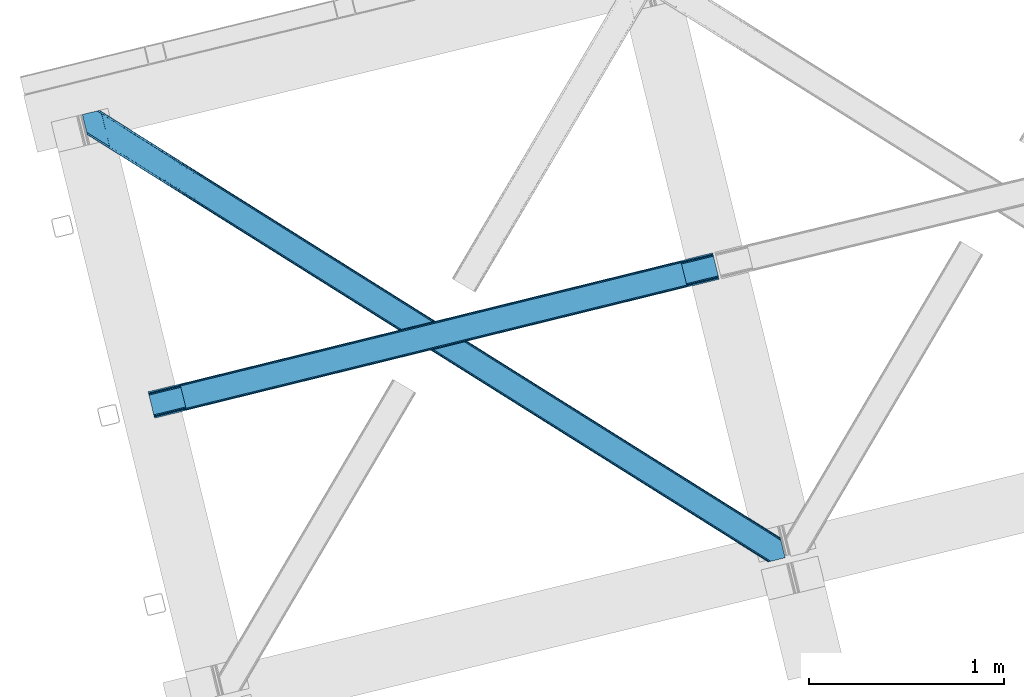
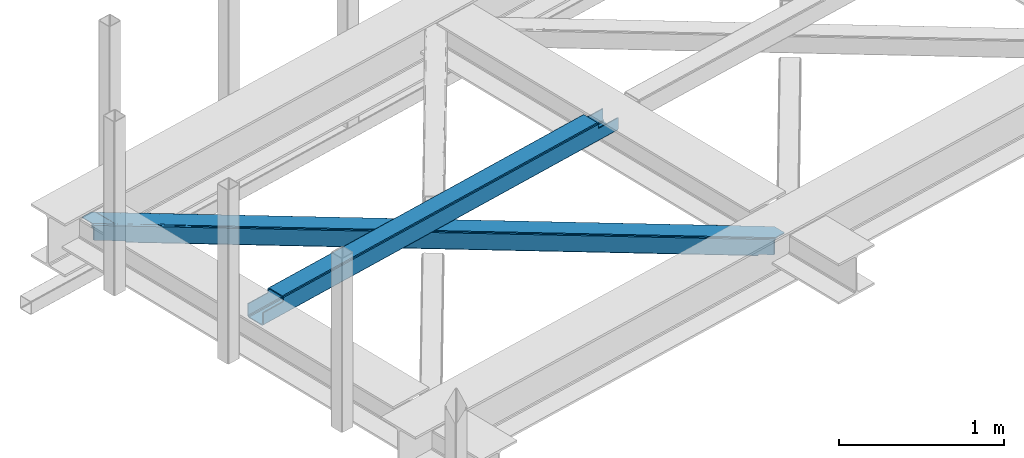
# One storey, part 18 of 66: 1 beam, 1 member.
"""IFC4 building model written with IfcOpenShell, lengths in millimetres."""

from ifc_helpers import new_model, entity, si_unit, converted_unit, derived_unit, direction, frame, origin, place, context, subcontext, project, spatial, triangles, polygons, material, type_object, element, save


model = new_model("IFC4")

# Units and contexts
model_context = context("Model", 3, precision=0.01, world=origin(), true_north=direction((6.12303176911189e-17, 1.0)))
plan_context = context("Plan", 3, precision=0.01, world=origin(), true_north=direction((6.12303176911189e-17, 1.0)))
body_context = subcontext(model_context, "Body", "Model", "MODEL_VIEW")
ifc_project = project(units=[si_unit("LENGTHUNIT", "METRE", prefix="MILLI"), si_unit("AREAUNIT", "SQUARE_METRE"), si_unit("VOLUMEUNIT", "CUBIC_METRE"), converted_unit("PLANEANGLEUNIT", "DEGREE", entity("IfcRatioMeasure", 0.0174532925199433), si_unit("PLANEANGLEUNIT", "RADIAN"), dimensions=[0, 0, 0, 0, 0, 0, 0]), si_unit("MASSUNIT", "GRAM", prefix="KILO"), derived_unit("MASSDENSITYUNIT", [(si_unit("MASSUNIT", "GRAM", prefix="KILO"), 1), (si_unit("LENGTHUNIT", "METRE"), -3)]), derived_unit("MOMENTOFINERTIAUNIT", [(si_unit("LENGTHUNIT", "METRE"), 4)]), si_unit("TIMEUNIT", "SECOND"), si_unit("FREQUENCYUNIT", "HERTZ"), si_unit("THERMODYNAMICTEMPERATUREUNIT", "DEGREE_CELSIUS"), derived_unit("THERMALTRANSMITTANCEUNIT", [(si_unit("MASSUNIT", "GRAM", prefix="KILO"), 1), (si_unit("THERMODYNAMICTEMPERATUREUNIT", "KELVIN"), -1), (si_unit("TIMEUNIT", "SECOND"), -3)]), derived_unit("VOLUMETRICFLOWRATEUNIT", [(si_unit("LENGTHUNIT", "METRE"), 3), (si_unit("TIMEUNIT", "SECOND"), -1)]), derived_unit("MASSFLOWRATEUNIT", [(si_unit("MASSUNIT", "GRAM", prefix="KILO"), 1), (si_unit("TIMEUNIT", "SECOND"), -1)]), derived_unit("ROTATIONALFREQUENCYUNIT", [(si_unit("TIMEUNIT", "SECOND"), -1)]), si_unit("ELECTRICCURRENTUNIT", "AMPERE"), si_unit("ELECTRICVOLTAGEUNIT", "VOLT"), si_unit("POWERUNIT", "WATT"), si_unit("FORCEUNIT", "NEWTON", prefix="KILO"), si_unit("ILLUMINANCEUNIT", "LUX"), si_unit("LUMINOUSFLUXUNIT", "LUMEN"), si_unit("LUMINOUSINTENSITYUNIT", "CANDELA"), derived_unit("USERDEFINED", [(si_unit("MASSUNIT", "GRAM", prefix="KILO"), -1), (si_unit("LENGTHUNIT", "METRE"), -2), (si_unit("TIMEUNIT", "SECOND"), 3), (si_unit("LUMINOUSFLUXUNIT", "LUMEN"), 1)]), derived_unit("LINEARVELOCITYUNIT", [(si_unit("LENGTHUNIT", "METRE"), 1), (si_unit("TIMEUNIT", "SECOND"), -1)]), si_unit("PRESSUREUNIT", "PASCAL"), derived_unit("USERDEFINED", [(si_unit("LENGTHUNIT", "METRE"), -2), (si_unit("MASSUNIT", "GRAM", prefix="KILO"), 1), (si_unit("TIMEUNIT", "SECOND"), -2)]), derived_unit("LINEARFORCEUNIT", [(si_unit("MASSUNIT", "GRAM", prefix="KILO"), 1), (si_unit("LENGTHUNIT", "METRE"), 1), (si_unit("TIMEUNIT", "SECOND"), -2), (si_unit("LENGTHUNIT", "METRE"), -1)]), derived_unit("PLANARFORCEUNIT", [(si_unit("MASSUNIT", "GRAM", prefix="KILO"), 1), (si_unit("LENGTHUNIT", "METRE"), 1), (si_unit("TIMEUNIT", "SECOND"), -2), (si_unit("LENGTHUNIT", "METRE"), -2)])], contexts=[model_context, plan_context])

# Site, building, storey
site_placement = place(None, origin())
site = spatial("IfcSite", under=ifc_project, at=site_placement, CompositionType="ELEMENT")
building_placement = place(site_placement, origin())
building = spatial("IfcBuilding", under=site, at=building_placement, CompositionType="ELEMENT")
storey_placement = place(building_placement, frame((0.0, 0.0, 19800.0)))
storey = spatial("IfcBuildingStorey", under=building, at=storey_placement, Name="06", CompositionType="ELEMENT", Elevation=19800.0)

# Beam
ifc_material = material(Name="Metal painted (White)")
beam_type = type_object("IfcBeamType", PredefinedType="BEAM")
beam_placement = place(storey_placement, frame((-60653.48, 4348.08, 3967.02)))
element("IfcBeam", 1, at=beam_placement, inside=storey, type_object=beam_type, material=ifc_material, ObjectType="Steel Beam", PredefinedType="BEAM", context=body_context, shape_type="Tessellation", body=[
    polygons([(195.600194800813, 47.1939241264168, 116.42075398189), (195.284716026293, 48.4881398473712, 123.117713426564), (2768.48559452428, 681.870165407978, 122.252244531349), (2768.80107329879, 680.575949687031, 115.555285086674), (194.386308486354, 52.1737543987761, 128.795119546125), (2767.58718698434, 685.555779959373, 127.92965065091), (193.041746584857, 57.6896663753656, 132.588638724685), (2766.24262508284, 691.071691935965, 131.723169829474), (191.455727682833, 64.1961281805546, 133.920742055655), (2764.65660618081, 697.578153741174, 133.055273160444), (169.904498669375, 152.607589262086, 133.920675186106), (2743.10537716735, 785.989614822707, 133.055206290887), (168.318479767342, 159.114051067314, 132.588562012879), (2741.51935826532, 792.496076627916, 131.723093117668), (166.973917865845, 164.629963043904, 128.795034490451), (2740.17479636383, 798.011988604507, 127.92956559524), (166.075510325905, 168.315577595304, 123.117622795697), (2739.27638882389, 801.697603155909, 122.25215390049), (165.760031551403, 169.60979331623, 116.420661393285), (2738.96091004938, 802.991818876847, 115.55519249807), (2737.30312320219, 809.792700498506, 100.498086491908), (2737.30312320219, 809.792700498503, 122.555187727575), (2737.61860197672, 808.498484777552, 129.252149129995), (2738.51700951664, 804.81287022615, 134.929560824745), (2739.86157141814, 799.296958249559, 138.723088347173), (2741.44759032016, 792.790496444363, 140.055201520396), (2766.314393028, 690.777272119517, 140.055278677568), (2767.90041193004, 684.270810314287, 138.723175346603), (2769.24497383153, 678.754898337697, 134.929656168038), (2770.14338137147, 675.069283786296, 129.252250048477), (2770.4588601463, 673.775068064068, 122.555290603803), (2770.45886014598, 673.775068065378, 100.498086491908), (2768.80107329879, 680.575949687035, 100.498086491908), (2738.96091004938, 802.99181887685, 100.498086491908), (165.760031551403, 169.609793316229, 101.477862600484), (195.600194800813, 47.1939241264141, 101.477862600484), (197.257981650628, 40.3930424940991, 101.477862600484), (197.257981648003, 40.3930425047588, 123.420759499018), (196.942502873492, 41.687258225697, 130.117718943693), (196.044095333553, 45.3728727770981, 135.795125063254), (194.699533432056, 50.8887847536882, 139.588644241814), (193.113514530032, 57.3952465588977, 140.920747572779), (168.246711822184, 159.408470883743, 140.920670415607), (166.660692920151, 165.914932688954, 139.588557242389), (165.316131018672, 171.430844665544, 135.795029719961), (164.417723478732, 175.116459216944, 130.117618025206), (164.102244704213, 176.410674937886, 123.420656622786), (164.102244704213, 176.410674937885, 101.477862600484), (2932.903318003, 720.968992071844, 99.4980864919125), (2932.903318003, 720.968992071844, 24.5000861794985), (31.4979500966005, 6.80088174160769, 25.4759431828536), (31.4979500966005, 6.80088174160444, 100.477862600484), (194.629175601386, 46.9549120412976, 100.477862600484), (1.65778684719041, 129.216750931422, 25.4758505942489), (2903.06315475359, 843.384861261661, 24.4999935908851), (2903.06315475359, 843.384861261658, 99.4980864919125), (2739.93192924881, 803.230830961967, 99.4980864919082), (1.65778684719041, 129.216750931419, 100.477862600484), (2934.5611048484, 714.168110457467, 17.5000909499932), (2934.56110485023, 714.168110450045, 99.4980864919168), (2771.42987934575, 674.0140801491, 99.4980864919082), (33.1557369624336, 4.30769958370547e-08, 100.477862600484), (33.1557369474987, 1.04887051577407e-07, 18.4759479533483), (2901.40536790641, 850.185742883315, 99.4980864919125), (2901.4053679064, 850.185742883316, 17.4999880737653), (8.66293703438714e-12, 136.017632553077, 18.4758450771204), (-8.66293703438714e-12, 136.017632553075, 100.477862600484), (163.131225504777, 176.171662852768, 100.477862600484), (2769.77209249822, 680.814961772152, 99.4980864919125), (2738.27414240162, 810.031712583623, 99.4980864919125), (2903.37863352809, 842.090645540723, 17.8030341462194), (2904.27704106803, 838.405030989319, 12.125628026654), (2905.62160296953, 832.889119012729, 8.33210884809829), (2907.20762187156, 826.38265720752, 7.00000551712847), (2928.75885088502, 737.971196125987, 7.00007238668162), (2930.34486978705, 731.464734320777, 8.33218555990442), (2931.68943168854, 725.948822344187, 12.1257130823282), (2932.58783922849, 722.263207792786, 17.8031247770826), (2934.24562607566, 715.462326171149, 10.8031295475774), (2933.34721853572, 719.147940722552, 5.12571785282298), (2932.00265663423, 724.663852699141, 1.33219033039485), (2930.41663773221, 731.17031450433, 7.715717638348e-05), (2905.54983502437, 833.183538829176, 4.33146851719357e-12), (2903.96381612233, 839.690000634401, 1.33210333096982), (2902.61925422084, 845.20591261099, 5.12562250952989), (2901.7208466809, 848.891527162392, 10.8030286290909), (196.286962448568, 40.1540304196412, 100.477862600484), (164.789012351976, 169.370781231112, 100.477862600484), (27.3534829786202, 23.8030857957493, 7.97592939004109), (28.9395018806444, 17.2966239905593, 9.30804256325955), (30.2840637821412, 11.7807120139697, 13.1015700856834), (31.1824713220808, 8.0950974625664, 18.7789817804377), (1.97326562170153, 127.922535210493, 18.7788911495702), (2.87167316163245, 124.236920659096, 13.1014850300135), (4.21623506312922, 118.721008682505, 9.30796585145342), (5.80225396516212, 112.214546877282, 7.9758625204836), (0.315478774519784, 134.723416832139, 11.7788856324504), (1.21388631445936, 131.037802280738, 6.10147951288935), (2.5584482159388, 125.521890304147, 2.30796033432496), (4.14446711798903, 119.015428498938, 0.975857003359465), (29.0112698258193, 17.0022041740919, 0.975934160527186), (30.5972887278435, 10.4957423688823, 2.30804733374998), (31.9418506293403, 4.97983039229176, 6.10157485618245), (32.8402581692798, 1.29421584089328, 11.7789865509282)], [[[1, 2, 3, 4]], [[2, 5, 6, 3]], [[5, 7, 8, 6]], [[7, 9, 10, 8]], [[11, 12, 10, 9]], [[11, 13, 14, 12]], [[13, 15, 16, 14]], [[15, 17, 18, 16]], [[17, 19, 20, 18]], [[21, 22, 23, 24, 25, 26, 27, 28, 29, 30, 31, 32, 33, 4, 3, 6, 8, 10, 12, 14, 16, 18, 20, 34]], [[35, 19, 17, 15, 13, 11, 9, 7, 5, 2, 1, 36, 37, 38, 39, 40, 41, 42, 43, 44, 45, 46, 47, 48]], [[42, 41, 28, 27]], [[41, 40, 29, 28]], [[40, 39, 30, 29]], [[39, 38, 31, 30]], [[27, 26, 43, 42]], [[47, 46, 23, 22]], [[46, 45, 24, 23]], [[45, 44, 25, 24]], [[44, 43, 26, 25]], [[33, 49, 50, 51, 52, 53, 1, 4]], [[54, 55, 56, 57, 20, 19, 35, 58]], [[59, 60, 61, 31, 38, 37, 62, 63]], [[64, 65, 66, 67, 68, 47, 22, 21]], [[61, 60, 49, 69]], [[64, 70, 57, 56]], [[65, 64, 56, 55, 71, 72, 73, 74, 75, 76, 77, 78, 50, 49, 60, 59, 79, 80, 81, 82, 83, 84, 85, 86]], [[87, 53, 52, 62]], [[67, 58, 88, 68]], [[89, 90, 76, 75]], [[90, 91, 77, 76]], [[91, 92, 78, 77]], [[92, 51, 50, 78]], [[54, 93, 71, 55]], [[93, 94, 72, 71]], [[94, 95, 73, 72]], [[95, 96, 74, 73]], [[89, 75, 74, 96]], [[66, 97, 98, 99, 100, 101, 102, 103, 104, 63, 62, 52, 51, 92, 91, 90, 89, 96, 95, 94, 93, 54, 58, 67]], [[63, 104, 79, 59]], [[104, 103, 80, 79]], [[103, 102, 81, 80]], [[102, 101, 82, 81]], [[100, 99, 84, 83]], [[99, 98, 85, 84]], [[98, 97, 86, 85]], [[97, 66, 65, 86]], [[83, 82, 101, 100]]], closed=False),
])

# Member
member_type = type_object("IfcMemberType", PredefinedType="BRACE")
member_placement = place(storey_placement, frame((-60991.5, 3609.34, 3824.0)))
element("IfcMember", 2, at=member_placement, inside=storey, type_object=member_type, ObjectType="Steel Horizontal Brace", PredefinedType="BRACE", context=body_context, shape_type="Tessellation", body=[
    triangles([(207.717553710936, 2101.81647491455, 0.0), (172.040661621089, 2248.17905273438, 0.0), (3404.48986816406, 219.293009948731, 0.0), (3440.16676025391, 72.9304321289064, 0.0), (202.587634277341, 2097.1307144165, 1.33247680664135), (208.508203124999, 2098.57423095703, 0.155804443358647), (3442.44104003906, 63.5952461242678, 1.33247680664135), (3445.65944824219, 50.3934356689456, 10.8039916992202), (3446.115234375, 48.5365722656252, 17.5012573242202), (187.951318359374, 2093.56290893555, 17.5012573242202), (189.755859375, 2094.00299835205, 10.8039916992202), (3444.37115478516, 55.6811943054204, 5.12526855468968), (194.895080566406, 2095.25582885742, 5.12526855468968), (3405.08983154297, 238.005530548096, 10.8039916992202), (3400.22036132812, 236.818103027344, 5.32758178711083), (167.836267089842, 2265.42799987793, 5.12526855468968), (166.547973632813, 2270.71604919434, 10.8039916992202), (3400.29477539063, 236.497192382813, 5.1694519042976), (3402.21558837891, 228.628195953369, 1.33247680664135), (169.766381835936, 2257.51394805908, 1.33247680664135), (3406.89437255859, 238.4456199646, 17.5012573242202), (166.092187499999, 2272.57291259766, 17.5012573242202), (3401.18774414063, 237.055007171631, 18.5197998046897), (3406.89437255859, 238.4456199646, 18.5197998046897), (3400.50406494141, 236.887575531006, 18.2267944335945), (3400.82032470703, 236.964315032959, 18.4453857421868), (3400.29012451172, 236.836125183106, 17.9035583496116), (3400.22036132812, 236.818103027344, 17.5198608398459), (3402.03885498047, 231.951248931885, 18.4453857421868), (3401.8388671875, 231.936424255372, 18.1454040527351), (3401.62027587891, 231.920146179199, 17.8198425292976), (3401.6109741211, 231.919564819336, 17.8058898925774), (3401.41563720703, 231.905030822754, 17.5198608398459), (3402.49464111328, 231.698357391358, 18.5197998046897), (3586.9019897461, 125.462400054932, 18.5197998046897), (3589.63670654297, 114.236631774902, 18.5197998046897), (204.378222656247, 2097.56731567383, 12.1248413085959), (208.508203124999, 2098.57423095703, 9.69243164062573), (199.648278808592, 2096.4150604248, 17.9802978515618), (198.420446777345, 2096.11566009521, 19.5011352539077), (187.951318359374, 2093.56290893555, 19.5011352539077), (25.3054321289019, 2195.64679412842, 19.5011352539077), (22.6823364257798, 2206.42113647461, 19.5011352539077), (3437.79016113281, 82.6876853942872, 6.99957275390625), (3404.5921875, 218.870652008057, 8.3320495605476), (3402.6620727539, 226.784703826905, 12.1248413085959), (3406.86646728516, 209.535466003418, 6.99957275390625), (3443.24099121094, 60.3181205749515, 17.5198608398459), (3441.99455566406, 65.4387382507325, 12.1248413085959), (3446.115234375, 48.5365722656252, 17.5198608398459), (3440.06444091797, 73.3527900695804, 8.3320495605476), (1232.85963134765, 1574.07833862305, 6.99957275390625), (640.584155273435, 1945.82774047852, 6.99957275390625), (602.800415039063, 1862.1026184082, 6.99957275390625), (1195.07589111328, 1490.35496063232, 6.99957275390625), (1825.13510742188, 1202.32951812744, 6.99957275390625), (1787.3467163086, 1118.60788421631, 6.99957275390625), (205.340954589839, 2111.57401885986, 6.99957275390625), (174.417260742186, 2238.42150878906, 6.99957275390625), (2971.89301757813, 375.112859344483, 6.99957275390625), (3009.68605957031, 458.831295776367, 6.99957275390625), (2379.62219238281, 746.86022644043, 6.99957275390625), (2417.41058349609, 830.580406951905, 6.99957275390625), (168.831555175777, 2261.33697052002, 18.501196289064), (166.092187499999, 2272.57291259766, 18.501196289064), (168.966430664063, 2260.78526000977, 17.8803039550803), (170.212866210939, 2255.67045593262, 12.1248413085959), (172.142980957033, 2247.75640411377, 8.3320495605476), (207.559423828126, 2102.47631835938, 8.8831787109375), (3444.59439697266, 58.9995964050295, 18.5197998046897), (3447.32911376953, 47.7738281250004, 18.5197998046897), (3447.04075927734, 47.9543403625489, 18.2849304199226), (3444.26883544922, 59.3173095703128, 18.2802795410171), (3446.71984863281, 48.1552001953128, 18.0198303222678), (3443.91536865234, 59.6588584899905, 18.0198303222678), (3446.40358886719, 48.3560600280766, 17.757055664064), (3443.62701416016, 59.9419807434083, 17.8058898925774), (3443.56655273437, 60.0004074096682, 17.7617065429695), (3534.35635986328, 2.65972137451172, 18.5197998046897), (3523.44539794922, 0.0, 18.5197998046897), (2962.59125976563, 360.290798950195, 24.5008300781265), (2963.29819335938, 361.418927764893, 17.8035644531265), (3532.92854003907, 2.31177749633798, 24.5008300781265), (2965.31667480469, 364.632103729248, 12.1248413085959), (596.224072265621, 1851.62128143311, 12.1248413085959), (599.242492675781, 1856.43029022217, 8.3320495605476), (594.205590820311, 1848.40868682861, 17.8035644531265), (593.498657226563, 1847.28026733398, 24.5008300781265), (22.9288330078125, 2205.40433807373, 24.5008300781265), (2968.33509521485, 369.440821838379, 8.3320495605476), (2370.3157836914, 732.038166046143, 24.5008300781265), (2371.02736816406, 733.16629486084, 17.8035644531265), (1778.75189208984, 1104.91366195679, 17.8035644531265), (1778.0449584961, 1103.78553314209, 24.5008300781265), (1186.48106689453, 1476.66102905273, 17.8035644531265), (1185.76948242187, 1475.53260955811, 24.5008300781265), (2373.04119873047, 736.379470825196, 12.1248413085959), (1780.77037353515, 1108.12683792114, 12.1248413085959), (1188.49489746094, 1479.87420501709, 12.1248413085959), (2376.05961914062, 741.188188934326, 8.3320495605476), (1783.78879394531, 1112.93555603027, 8.3320495605476), (1191.51331787109, 1484.68263244629, 8.3320495605476), (2965.14924316407, 350.42105255127, 122.499499511719), (2371.32037353516, 723.143650817872, 122.499499511719), (3523.44539794922, 0.0, 122.499499511719), (1777.49150390625, 1095.86624908447, 122.499499511719), (1183.66728515625, 1468.58884735107, 122.499499511719), (589.838415527345, 1841.31144561768, 122.499499511719), (25.3054321289019, 2195.64679412842, 122.499499511719), (3532.92854003907, 2.31177749633798, 115.499926757813), (22.9288330078125, 2205.40433807373, 115.499926757813), (3534.73308105468, 2.75157623291034, 122.197192382813), (22.4776977539077, 2207.26120147705, 122.197192382813), (3539.87230224609, 4.00440673828143, 127.873590087893), (21.1894042968706, 2212.54925079346, 127.873590087893), (3547.56485595703, 5.87958297729529, 131.668707275392), (19.2592895507769, 2220.46330261231, 131.668707275392), (3556.63872070312, 8.09136657714862, 133.001184082033), (16.9803588867144, 2229.79819793701, 133.001184082033), (3525.24993896484, 0.439798736572357, 129.196765136719), (3530.38916015625, 1.69262924194345, 134.87548828125), (3547.15557861328, 5.77958908081064, 140.00075683594), (3612.207421875, 21.6376327514649, 140.00075683594), (3612.207421875, 21.6376327514649, 133.001184082033), (3538.08171386718, 3.5678054809573, 138.668280029298), (168.515295410158, 2261.63113861084, 18.7407165527366), (165.808483886714, 2272.75313415527, 18.7360656738274), (168.171130371091, 2261.94914245606, 19.0011657714858), (165.487573242186, 2272.95428466797, 19.0011657714858), (167.826965332031, 2262.26714630127, 19.2592895507805), (165.166662597658, 2273.1548538208, 19.2639404296897), (167.506054687496, 2262.56131439209, 19.5011352539077), (164.878308105464, 2273.33565673828, 19.5011352539077), (78.2928955078096, 2318.55673370361, 19.5011352539077), (88.7666748046831, 2321.10948486328, 19.5011352539077), (649.178979492186, 1959.52167205811, 17.8035644531265), (3018.28088378906, 472.525227355957, 17.8035644531265), (3016.26705322265, 469.312051391602, 12.1248413085959), (3018.99246826172, 473.653356170655, 24.5008300781265), (3589.27858886719, 115.704856109619, 24.5008300781265), (649.885913085935, 1960.64951019287, 24.5008300781265), (79.2788818359331, 2318.79741668701, 24.5008300781265), (3013.2486328125, 464.503333282471, 8.3320495605476), (644.142077636716, 1951.49948730469, 8.3320495605476), (647.160498046876, 1956.30849609375, 12.1248413085959), (2420.97315673828, 836.252444458008, 8.3320495605476), (1828.69768066406, 1208.00155563355, 8.3320495605476), (1236.42220458984, 1579.75066680908, 8.3320495605476), (2423.99157714844, 841.061162567139, 12.1248413085959), (1831.71610107422, 1212.81027374268, 12.1248413085959), (1239.440625, 1584.55909423828, 12.1248413085959), (2426.00540771485, 844.274338531495, 17.8035644531265), (1833.72993164062, 1216.02344970703, 17.8035644531265), (1241.4544555664, 1587.77227020264, 17.8035644531265), (2426.7169921875, 845.402467346191, 24.5008300781265), (1834.43686523438, 1217.15157852173, 24.5008300781265), (1242.16138916015, 1588.90068969727, 24.5008300781265), (1247.70523681641, 1593.6864440918, 122.499499511719), (653.811254882814, 1966.45031890869, 122.499499511719), (1841.59921875, 1220.9225692749, 122.499499511719), (3586.9019897461, 125.462400054932, 122.499499511719), (2435.4932006836, 848.158403778076, 122.499499511719), (3029.38253173828, 475.39423828125, 122.499499511719), (88.7666748046831, 2321.10948486328, 122.499499511719), (3591.02266845703, 108.559943389893, 127.873590087893), (3588.64141845703, 118.317487335205, 134.87548828125), (3590.57153320313, 110.403726196289, 138.668280029298), (3592.94813232422, 100.646182250977, 131.668707275392), (3595.22706298828, 91.3109962463382, 133.001184082033), (3592.84581298828, 101.068540191651, 140.00075683594), (3589.734375, 113.847992706299, 122.197192382813), (3587.353125, 123.605536651612, 129.196765136719), (3589.27858886719, 115.704856109619, 115.499926757813), (55.5687011718765, 2313.01811828613, 133.001184082033), (0.0, 2299.47185211182, 133.001184082033), (79.2788818359331, 2318.79741668701, 115.499926757813), (64.6425659179658, 2315.22961120606, 131.668707275392), (72.3351196289077, 2317.105078125, 127.873590087893), (77.474340820314, 2318.35790863037, 122.197192382813), (76.0604736328096, 2318.01316223145, 138.000878906252), (81.8229125976577, 2319.41656494141, 134.87548828125), (86.962133789064, 2320.66939544678, 129.196765136719), (0.0, 2299.47185211182, 138.000878906252), (24.8542968749971, 2197.50365753174, 129.196765136719), (23.5660034179673, 2202.79170684815, 134.87548828125), (22.1195800781206, 2208.71634521484, 138.000878906252), (98.1893554687485, 2304.12331237793, 138.000878906252), (139.386840820313, 2135.11211700439, 138.000878906252), (599.144824218747, 1856.1337966919, 140.00075683594), (139.824023437497, 2137.54568939209, 139.000817871096), (140.051916503908, 2136.3818069458, 138.668280029298), (137.842749023439, 2145.67368164063, 140.00075683594), (592.563830566403, 1845.6524597168, 134.87548828125), (139.805419921875, 2135.0249130249, 138.075292968751), (595.582250976564, 1850.46146850586, 138.668280029298), (139.917041015622, 2135.65917663574, 138.352020263672), (140.033312988278, 2136.29576568604, 138.631072998047), (2974.45100097657, 365.243403625489, 140.00075683594), (2970.88842773438, 359.571075439454, 138.668280029298), (2967.87000732422, 354.762357330323, 134.87548828125), (2965.85617675781, 351.549181365967, 129.196765136719), (590.549999999996, 1842.43986511231, 129.196765136719), (2372.0273071289, 724.2720703125, 129.196765136719), (1778.2030883789, 1096.99437789917, 129.196765136719), (1184.37421875, 1469.7172668457, 129.196765136719), (2374.04578857421, 727.484955596924, 134.87548828125), (1780.21691894531, 1100.20755386353, 134.87548828125), (1186.39270019531, 1472.93044281006, 134.87548828125), (2377.06420898438, 732.293673706055, 138.668280029298), (1783.23533935547, 1105.01627197266, 138.668280029298), (1189.41112060547, 1477.73887023926, 138.668280029298), (2380.62213134766, 737.965711212158, 140.00075683594), (1786.79791259766, 1110.68830947876, 140.00075683594), (1192.96904296875, 1483.41119842529, 140.00075683594), (651.085839843749, 1962.10930480957, 134.87548828125), (98.7056030273452, 2303.62683105469, 138.075292968751), (99.1985961914033, 2302.47515716553, 138.384576416018), (648.067419433595, 1957.30087738037, 138.668280029298), (99.5985717773438, 2301.53800506592, 138.633398437501), (644.509497070314, 1951.62854919434, 140.00075683594), (100.184582519527, 2300.16425170898, 139.000817871096), (102.165856933592, 2292.03625946045, 140.00075683594), (3028.67559814453, 474.266109466553, 129.196765136719), (3026.66176757812, 471.052933502197, 134.87548828125), (3023.64334716797, 466.244215393067, 138.668280029298), (3020.08077392578, 460.572177886963, 140.00075683594), (653.104321289058, 1965.32248077393, 129.196765136719), (2429.74936523438, 839.008380889893, 138.668280029298), (2426.18679199219, 833.336052703858, 140.00075683594), (1832.2974609375, 1206.10021820068, 140.00075683594), (1835.85538330078, 1211.77254638672, 138.668280029298), (1238.40347900391, 1578.86409301758, 140.00075683594), (1241.96140136719, 1584.53642120361, 138.668280029298), (2432.76778564453, 843.817098999024, 134.87548828125), (1838.87380371094, 1216.58126449585, 134.87548828125), (1244.97982177734, 1589.34484863281, 134.87548828125), (2434.78161621094, 847.030274963379, 129.196765136719), (1840.89228515625, 1219.79414978027, 129.196765136719), (1246.99830322265, 1592.55802459717, 129.196765136719)], [[1, 2, 3], [3, 4, 1], [5, 6, 4], [4, 7, 5], [8, 9, 10], [10, 11, 8], [12, 8, 11], [11, 13, 12], [7, 12, 13], [13, 5, 7], [6, 1, 4], [14, 15, 16], [16, 17, 14], [18, 19, 20], [19, 3, 2], [2, 20, 19], [20, 16, 18], [15, 18, 16], [21, 14, 17], [17, 22, 21], [23, 21, 24], [25, 23, 26], [23, 25, 27], [23, 27, 28], [21, 23, 28], [28, 15, 14], [14, 21, 28], [26, 29, 30], [25, 30, 31], [27, 32, 33], [27, 31, 32], [33, 28, 27], [31, 27, 25], [30, 25, 26], [23, 34, 29], [29, 26, 23], [34, 24, 35], [24, 34, 23], [35, 36, 34], [37, 38, 5], [37, 5, 13], [13, 11, 39], [38, 6, 5], [39, 37, 13], [11, 10, 40], [41, 40, 10], [11, 40, 39], [42, 43, 40], [40, 41, 42], [3, 44, 4], [45, 19, 46], [33, 15, 28], [18, 33, 46], [33, 18, 15], [3, 19, 45], [46, 19, 18], [3, 47, 44], [45, 47, 3], [8, 48, 9], [48, 12, 49], [12, 48, 8], [50, 9, 48], [49, 7, 51], [51, 4, 44], [4, 51, 7], [49, 12, 7], [52, 53, 54], [54, 55, 52], [55, 56, 52], [56, 55, 57], [53, 58, 54], [53, 59, 58], [60, 61, 62], [61, 60, 47], [44, 47, 60], [63, 62, 61], [57, 63, 56], [62, 63, 57], [17, 22, 64], [22, 65, 64], [66, 17, 64], [66, 16, 17], [67, 16, 66], [20, 67, 68], [67, 20, 16], [2, 20, 68], [68, 59, 2], [69, 38, 6], [69, 1, 58], [1, 59, 58], [59, 1, 2], [69, 6, 1], [70, 71, 72], [72, 73, 70], [73, 72, 74], [74, 75, 73], [75, 76, 77], [75, 74, 76], [76, 78, 77], [78, 76, 50], [50, 48, 78], [71, 70, 79], [79, 80, 71], [81, 70, 73], [73, 82, 81], [73, 75, 82], [75, 77, 82], [83, 79, 70], [70, 81, 83], [82, 77, 78], [78, 84, 82], [78, 48, 84], [48, 49, 84], [54, 58, 69], [85, 86, 38], [86, 69, 38], [87, 85, 37], [88, 87, 39], [39, 40, 88], [88, 40, 89], [43, 89, 40], [37, 39, 87], [38, 37, 85], [69, 86, 54], [51, 44, 90], [60, 90, 44], [49, 51, 84], [90, 84, 51], [81, 82, 91], [92, 91, 82], [91, 92, 93], [93, 94, 91], [94, 93, 95], [95, 96, 94], [96, 95, 87], [87, 88, 96], [82, 84, 97], [97, 92, 82], [92, 97, 98], [98, 93, 92], [93, 98, 99], [99, 95, 93], [95, 99, 85], [85, 87, 95], [84, 90, 100], [100, 97, 84], [97, 100, 101], [101, 98, 97], [98, 101, 102], [102, 99, 98], [99, 102, 86], [86, 85, 99], [90, 60, 100], [62, 100, 60], [100, 62, 101], [57, 101, 62], [101, 57, 102], [55, 102, 57], [102, 55, 86], [54, 86, 55], [9, 103, 104], [71, 105, 72], [71, 80, 105], [105, 74, 72], [50, 105, 103], [50, 76, 105], [76, 74, 105], [9, 50, 103], [106, 10, 9], [10, 107, 108], [109, 41, 108], [106, 107, 10], [106, 9, 104], [10, 108, 41], [42, 41, 109], [81, 110, 83], [110, 81, 91], [110, 94, 111], [94, 110, 91], [88, 89, 111], [96, 111, 94], [111, 96, 88], [112, 110, 111], [111, 113, 112], [114, 112, 113], [113, 115, 114], [116, 114, 115], [115, 117, 116], [118, 116, 117], [117, 119, 118], [112, 120, 121], [118, 122, 123], [123, 124, 118], [118, 116, 122], [116, 125, 122], [114, 125, 116], [121, 125, 114], [112, 105, 120], [110, 105, 112], [121, 114, 112], [80, 83, 79], [110, 80, 105], [83, 80, 110], [65, 64, 126], [126, 127, 65], [127, 126, 128], [128, 129, 127], [129, 128, 130], [130, 131, 129], [131, 130, 132], [132, 133, 131], [134, 135, 133], [133, 132, 134], [136, 66, 67], [137, 138, 33], [138, 46, 33], [139, 29, 34], [34, 140, 139], [34, 36, 140], [139, 137, 32], [32, 31, 139], [30, 29, 139], [139, 31, 30], [141, 130, 128], [141, 132, 130], [128, 136, 141], [64, 136, 126], [128, 126, 136], [64, 66, 136], [132, 141, 142], [142, 134, 132], [33, 32, 137], [45, 46, 143], [138, 143, 46], [47, 45, 61], [143, 61, 45], [53, 144, 59], [68, 59, 144], [144, 145, 68], [67, 68, 145], [67, 145, 136], [61, 143, 146], [146, 63, 61], [63, 146, 147], [147, 56, 63], [56, 147, 148], [148, 52, 56], [52, 148, 144], [144, 53, 52], [143, 138, 146], [149, 146, 138], [146, 149, 147], [150, 147, 149], [147, 150, 148], [151, 148, 150], [148, 151, 144], [145, 144, 151], [138, 137, 152], [152, 149, 138], [149, 152, 153], [153, 150, 149], [150, 153, 154], [154, 151, 150], [151, 154, 136], [136, 145, 151], [137, 139, 152], [155, 152, 139], [152, 155, 153], [156, 153, 155], [153, 156, 154], [157, 154, 156], [154, 157, 136], [141, 136, 157], [158, 22, 159], [22, 158, 160], [161, 35, 24], [21, 160, 162], [21, 163, 24], [160, 21, 22], [24, 163, 161], [162, 163, 21], [164, 159, 65], [164, 65, 127], [22, 65, 159], [129, 164, 127], [164, 129, 131], [131, 133, 164], [135, 164, 133], [165, 166, 167], [165, 167, 168], [169, 168, 170], [171, 166, 165], [124, 169, 123], [170, 123, 169], [168, 167, 170], [172, 166, 171], [35, 161, 173], [140, 35, 173], [35, 140, 36], [172, 171, 161], [171, 173, 161], [119, 174, 169], [174, 119, 175], [169, 118, 119], [124, 118, 169], [156, 173, 176], [173, 155, 139], [156, 155, 173], [139, 140, 173], [157, 176, 141], [176, 157, 156], [142, 141, 176], [168, 169, 174], [174, 177, 168], [165, 168, 177], [177, 178, 165], [171, 165, 178], [178, 179, 171], [173, 171, 179], [179, 176, 173], [177, 174, 180], [181, 178, 180], [177, 180, 178], [179, 181, 182], [174, 183, 180], [174, 175, 183], [179, 178, 181], [164, 176, 179], [176, 164, 135], [142, 135, 134], [135, 142, 176], [164, 179, 182], [111, 42, 109], [184, 113, 109], [113, 184, 185], [113, 111, 109], [89, 42, 111], [43, 42, 89], [115, 113, 185], [186, 119, 117], [119, 186, 183], [183, 175, 119], [117, 115, 186], [186, 115, 185], [180, 186, 187], [180, 183, 186], [188, 187, 186], [189, 190, 191], [189, 192, 190], [193, 194, 188], [188, 185, 193], [188, 186, 185], [195, 196, 194], [195, 191, 196], [194, 193, 195], [197, 195, 189], [125, 122, 198], [198, 199, 125], [121, 125, 199], [199, 200, 121], [120, 121, 200], [200, 201, 120], [105, 120, 201], [201, 103, 105], [108, 202, 109], [184, 109, 202], [202, 193, 184], [185, 184, 193], [103, 201, 104], [203, 104, 201], [104, 203, 204], [204, 106, 104], [106, 204, 205], [205, 107, 106], [107, 205, 108], [202, 108, 205], [201, 200, 203], [206, 203, 200], [203, 206, 204], [207, 204, 206], [204, 207, 208], [208, 205, 204], [205, 208, 193], [193, 202, 205], [200, 199, 209], [209, 206, 200], [206, 209, 210], [210, 207, 206], [207, 210, 208], [211, 208, 210], [208, 211, 193], [195, 193, 211], [199, 198, 212], [212, 209, 199], [209, 212, 213], [213, 210, 209], [210, 213, 214], [214, 211, 210], [211, 214, 189], [189, 195, 211], [215, 216, 217], [217, 218, 215], [217, 219, 218], [187, 215, 181], [181, 180, 187], [219, 220, 218], [219, 221, 220], [221, 222, 220], [172, 161, 223], [163, 223, 161], [166, 172, 224], [223, 224, 172], [167, 166, 225], [224, 225, 166], [170, 167, 226], [225, 226, 167], [215, 227, 182], [182, 181, 215], [227, 159, 164], [164, 182, 227], [226, 225, 228], [228, 229, 226], [229, 228, 230], [231, 230, 228], [230, 231, 232], [233, 232, 231], [232, 233, 218], [218, 220, 232], [225, 224, 234], [234, 228, 225], [228, 234, 235], [235, 231, 228], [231, 235, 236], [236, 233, 231], [233, 236, 215], [215, 218, 233], [224, 223, 234], [237, 234, 223], [234, 237, 235], [238, 235, 237], [235, 238, 236], [239, 236, 238], [236, 239, 215], [227, 215, 239], [223, 163, 162], [162, 237, 223], [237, 162, 160], [160, 238, 237], [238, 160, 158], [158, 239, 238], [239, 158, 159], [159, 227, 239], [214, 232, 189], [232, 214, 230], [213, 230, 214], [230, 213, 229], [222, 192, 220], [189, 220, 192], [220, 189, 232], [170, 226, 198], [198, 122, 170], [123, 170, 122], [226, 212, 198], [212, 229, 213], [226, 229, 212], [197, 190, 221], [221, 219, 197], [219, 217, 194], [217, 216, 194], [222, 221, 192], [190, 192, 221]]),
])

save(model, "model.ifc")
